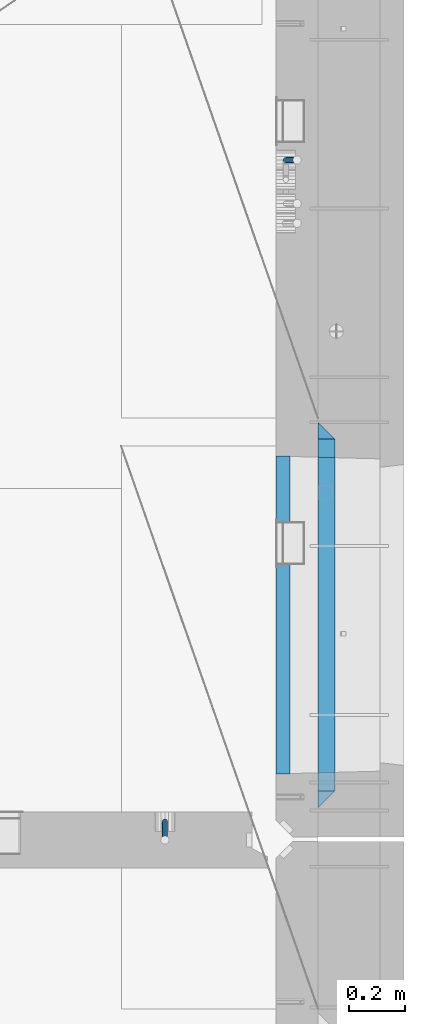
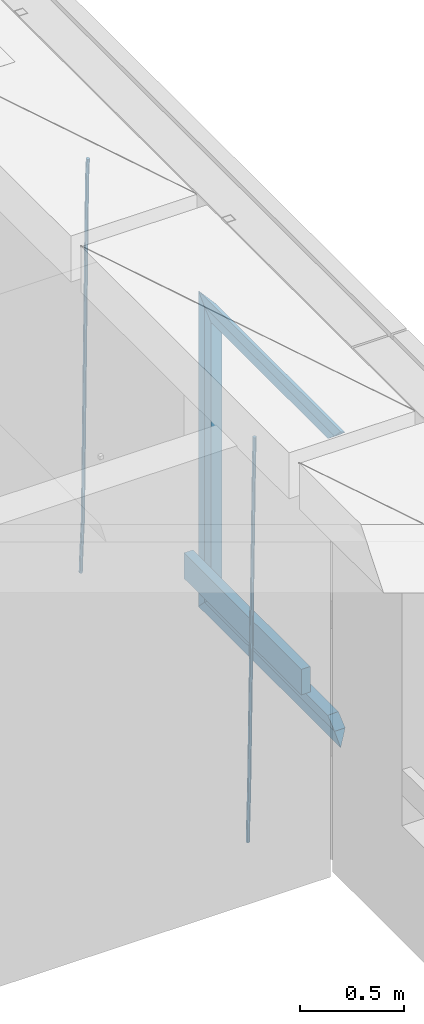
# One storey, part 132 of 352: 9 beams, 2 elements without a shape of their own.
"""IFC2X3 building model written with IfcOpenShell, lengths in millimetres."""

from ifc_helpers import new_model, si_unit, frame, origin_with_axes, place, context, subcontext, project, spatial, faceted_brep, material, type_object, element, aggregate, save


model = new_model("IFC2X3")

# Units and contexts
model_context = context("Model", 3, precision=1e-05, world=origin_with_axes())
body_context = subcontext(model_context, "Body", "Model", "MODEL_VIEW")
ifc_project = project(units=[si_unit("LENGTHUNIT", "METRE", prefix="MILLI"), si_unit("AREAUNIT", "SQUARE_METRE"), si_unit("VOLUMEUNIT", "CUBIC_METRE"), si_unit("MASSUNIT", "GRAM", prefix="KILO"), si_unit("TIMEUNIT", "SECOND"), si_unit("PLANEANGLEUNIT", "RADIAN"), si_unit("SOLIDANGLEUNIT", "STERADIAN"), si_unit("THERMODYNAMICTEMPERATUREUNIT", "DEGREE_CELSIUS"), si_unit("LUMINOUSINTENSITYUNIT", "LUMEN")], contexts=[model_context])

# Site, building, storey
site_placement = place(None, origin_with_axes())
site = spatial("IfcSite", under=ifc_project, at=site_placement, CompositionType="ELEMENT")
building_placement = place(site_placement, origin_with_axes())
building = spatial("IfcBuilding", under=site, at=building_placement, CompositionType="ELEMENT")
storey_placement = place(building_placement, origin_with_axes())
storey = spatial("IfcBuildingStorey", under=building, at=storey_placement, Name="6", CompositionType="ELEMENT", Elevation=0.0)

# Assembly, beam
assembly_1_placement = place(storey_placement, origin_with_axes())
assembly_1 = element("IfcElementAssembly", 1, at=assembly_1_placement, inside=storey, AssemblyPlace="NOTDEFINED", PredefinedType="REINFORCEMENT_UNIT")
ifc_material_1 = material()
beam_type_1 = type_object("IfcBeamType", Name="D20", PredefinedType="NOTDEFINED")
beam_1_placement = place(assembly_1_placement, frame((34514.9999999961, 17044.9997581385, 96990.0), z_axis=(0.00020576299992186, -0.999642804629538, -0.0267249099901004), x_axis=(-4.30000201928125e-08, -0.0267249099948059, 0.999642825806181)))
beam_1 = element("IfcBeam", 2, at=beam_1_placement, type_object=beam_type_1, material=ifc_material_1, Name="JM20", ObjectType="D20", context=body_context, shape_type="Brep", body=[
    faceted_brep([(0.0, -10.0, 0.0), (-4.19531716033816e-08, -7.07106781186667, -7.07106781187031), (60.4266690400545, -7.0710677960451, -7.07106780570757), (60.4266690441291, -9.99999998418934, 6.15546014159918e-09), (0.0, 0.0, -10.0), (60.426669036824, 1.58106558956206e-08, -9.99999999384454), (4.196772351861e-08, 7.07106781186303, -7.07106781186667), (60.4266690363438, 7.07106782768096, -7.07106780570757), (0.0, 10.0, 0.0), (60.4266690388904, 10.0000000158179, 6.15182216279209e-09), (4.196772351861e-08, 7.07106781185939, 7.07106781185939), (60.4266690429649, 7.07106782768096, 7.07106781802577), (0.0, 0.0, 10.0), (60.4266690461809, 1.58179318532348e-08, 10.0000000061555), (-4.19531716033816e-08, -7.07106781187031, 7.07106781185939), (60.4266690466611, -7.07106779605238, 7.07106781802213), (61.0378400410118, -7.07106779588503, -7.07106780564936), (60.991799419251, -9.99999998403655, 6.21366780251265e-09), (61.0569027789461, 1.5985278878361e-08, -9.99999999378269), (61.0378209396877, 7.07106782784831, -7.07106780564936), (60.9917724058905, 10.0000000159635, 6.21366780251265e-09), (60.9457317841297, 7.07106782781193, 7.0710678180767), (60.9266690461809, 1.59488990902901e-08, 10.0000000062028), (60.9457508854539, -7.07106779591413, 7.0710678180767), (61.6489592143771, -7.07106614513759, -7.06310863441468), (61.5568818710308, -9.9999984576425, 0.00735959856683621), (61.6870830769039, 1.71821739058942e-06, -9.99179257185824), (61.6489210170112, 7.07106947854481, -7.06310888312146), (61.556827851804, 10.0000015422847, 0.00735924683976918), (61.4647505084577, 7.07106922979438, 7.07782747982128), (61.4266266459163, 1.36643211590126e-06, 10.0065114172685), (61.464788705809, -7.07106639389531, 7.07782772852806), (176.543135720174, -7.07075579406956, -5.56673531796696), (176.451058376813, -9.99968810657447, 1.50373291501455), (176.581259582701, 0.000312069292704109, -8.49541925541052), (176.543097522794, 7.07137982961285, -5.56673556667374), (176.451004357587, 10.00031189336, 1.50373256329476), (176.35892701424, 7.07137958085514, 8.57420079627263), (176.320803151699, 0.000311717507429421, 11.5028847337162), (176.358965211621, -7.07075604281999, 8.57420104497578), (177.098753836006, -7.07075429323595, -5.55949898843028), (176.98362511232, -9.99968666800123, 1.510669025065), (177.146421932586, 0.000313595905026887, -8.48805862247536), (177.098706077581, 7.07138133041735, -5.55949936166144), (176.983557571715, 10.0003133318824, 1.51066849724157), (176.868428848029, 7.07138095712435, 8.58083651073321), (176.820760751449, 0.000313067976094317, 11.5093961447819), (176.868476606425, -7.07075466652896, 8.58083688396073), (177.654312950661, -7.07075204110879, -5.54863964998367), (177.516135294456, -9.99968450931192, 1.52107783331303), (177.711524267797, 0.000315886711177882, -8.47701274570863), (177.654255632195, 7.07138358250813, -5.54864021007961), (177.516054233929, 10.0003154905207, 1.5210770412159), (177.377876577739, 7.0713830223176, 8.59079452451624), (177.320665260588, 0.000315094497636892, 11.5191676202448), (177.377933896176, -7.07075260129932, 8.59079508461218), (299.499456785634, -7.07025810522464, -3.16697112782276), (299.361279129444, -9.99919057342777, 3.90274635547394), (299.556668102785, 0.000809822595329024, -6.09534422354773), (299.499399467197, 7.07187751838501, -3.1669716879187), (299.361198068917, 10.0008094264049, 3.90274556338045), (299.223020412712, 7.07187695819448, 10.9724630466735), (299.165809095575, 0.000809030381788034, 13.9008361423985), (299.223077731163, -7.07025866542244, 10.9724636067695), (300.03174732349, -7.07025594743027, -3.15656661289177), (299.971788958996, -9.99918809853989, 3.91467979818117), (300.056572611924, 0.000811849109595641, -6.08557274808481), (300.031722507032, 7.07187967631762, -3.15656653768019), (299.971753863239, 10.0008119014747, 3.91467990454839), (299.91179549876, 7.07187975035777, 10.9859263156177), (299.886970210311, 0.000811953817901667, 13.9149324508144), (299.911820315203, -7.0702558733974, 10.9859262404061), (300.564137759997, -7.07025623699155, -3.15794273276697), (300.582413367199, -9.99918843065097, 3.91310145956595), (300.556570941641, 0.000811577163403854, -6.0868651410201), (300.564145451674, 7.07187938674906, -3.15794274158179), (300.582424244858, 10.0008115693345, 3.91310144710224), (300.600699852032, 7.07187937566778, 10.9841456394352), (300.608266670402, 0.000811561512819026, 13.9130680476919), (300.600692160384, -7.07025624805829, 10.98414564825), (2294.16589219622, -7.0713405251372, -8.31099358700158), (2294.1841678034, -10.0002727187966, -1.23994939466866), (2294.15832537785, -0.000272710982244462, -11.2399159952547), (2294.16589988787, 7.07079509858886, -8.31099359582004), (2294.18417868105, 9.99972728118883, -1.23994940713601), (2294.20245428824, 7.07079508752213, 5.83109478519327), (2294.2100211066, -0.00027272663282929, 8.76001719345368), (2294.20244659658, -7.07134053620393, 5.83109479401173), (2294.7782683276, -7.07134085819416, -8.31257645345977), (2294.72126025338, -10.000273010919, -1.24133766827799), (2294.84007459224, -0.000273081772320438, -11.2416781768807), (2294.87047377572, 7.07079471537872, -8.31281477453012), (2294.85165844864, 9.9997269181622, -1.24167470516841), (2294.7946503744, 7.07079476544459, 5.82956408001337), (2294.73284410976, -0.000273010977252852, 8.75866580342336), (2294.7024449263, -7.07134080815013, 5.82980240107645), (2295.39054023061, -7.0793250091956, -8.30442771922026), (2295.25826128852, -10.0072756143927, -1.23419071494573), (2295.52170777075, -0.00916171800054144, -11.2326063125765), (2295.57492774284, 7.06160849139269, -8.30343918807193), (2295.51902460904, 9.99102432676591, -1.23279272078435), (2295.38674566693, 7.06307372157607, 5.83744428349019), (2295.25557812679, -0.0070895696117077, 8.76562287684646), (2295.20235815471, -7.07785977901949, 5.83645575234186), (2317.1947101649, -7.36365585014573, -8.01423575520312), (2317.06243122277, -10.2916064553428, -0.94399875092131), (2317.32587770502, -0.293492558957951, -10.9424143485521), (2317.37909767711, 6.77727765044983, -8.01324722405116), (2317.32319454331, 9.70669348581578, -0.942600756767206), (2317.1909156012, 6.77874288063322, 6.12763624751096), (2317.05974806109, -0.291420410569117, 9.0558148408636), (2317.00652808898, -7.36219061996962, 6.12664771636264), (2317.83015404257, -7.37194216843636, -8.00577862486898), (2317.72252095213, -10.300214160583, -0.935213608652703), (2317.90419832576, -0.301033978277701, -10.9347174723516), (2317.90127966482, 6.77046829039318, -8.00629749759901), (2317.82310777172, 9.70017451494641, -0.935947405505431), (2317.71547468127, 6.77190252279979, 6.13461761071085), (2317.64143039809, -0.29900566735887, 9.06355645819713), (2317.64434905903, -7.37050793602975, 6.13513648344451), (2318.46565174212, -7.3700661537805, -7.99751648408346), (2318.38266643914, -10.2982456018653, -0.926623872735945), (2318.48256818345, -0.299336209594912, -10.9272153854981), (2318.42350634121, 6.77200652527245, -7.99954269419686), (2318.32306384158, 9.70166538090416, -0.929489366557391), (2318.2400785386, 6.77348593281204, 6.14140324480104), (2318.22316209726, -0.297244011366274, 9.07110214621207), (2318.2822239395, -7.36858674623363, 6.1434294549108), (2418.48643733139, -7.07180401323421, -6.70013846199799), (2418.4034520284, -9.99998346132634, 0.370754149349523), (2418.5033537727, -0.00107406904135132, -9.62983736341266), (2418.44429193046, 7.07026866581873, -6.70216467211139), (2418.34384943081, 9.99992752145772, 0.367888655531715), (2418.26086412782, 7.0717480733656, 7.43878126688651), (2418.24394768651, 0.00101812917273492, 10.3684801682975), (2418.30300952874, -7.07032460568735, 7.44080747699627)], [[[0, 1, 2, 3]], [[1, 4, 5, 2]], [[4, 6, 7, 5]], [[6, 8, 9, 7]], [[8, 10, 11, 9]], [[10, 12, 13, 11]], [[12, 14, 15, 13]], [[14, 0, 3, 15]], [[14, 12, 10, 8, 6, 4, 1, 0]], [[3, 2, 16, 17]], [[2, 5, 18, 16]], [[5, 7, 19, 18]], [[7, 9, 20, 19]], [[9, 11, 21, 20]], [[11, 13, 22, 21]], [[13, 15, 23, 22]], [[15, 3, 17, 23]], [[17, 16, 24, 25]], [[16, 18, 26, 24]], [[18, 19, 27, 26]], [[19, 20, 28, 27]], [[20, 21, 29, 28]], [[21, 22, 30, 29]], [[22, 23, 31, 30]], [[23, 17, 25, 31]], [[25, 24, 32, 33]], [[24, 26, 34, 32]], [[26, 27, 35, 34]], [[27, 28, 36, 35]], [[28, 29, 37, 36]], [[29, 30, 38, 37]], [[30, 31, 39, 38]], [[31, 25, 33, 39]], [[33, 32, 40, 41]], [[32, 34, 42, 40]], [[34, 35, 43, 42]], [[35, 36, 44, 43]], [[36, 37, 45, 44]], [[37, 38, 46, 45]], [[38, 39, 47, 46]], [[39, 33, 41, 47]], [[41, 40, 48, 49]], [[40, 42, 50, 48]], [[42, 43, 51, 50]], [[43, 44, 52, 51]], [[44, 45, 53, 52]], [[45, 46, 54, 53]], [[46, 47, 55, 54]], [[47, 41, 49, 55]], [[49, 48, 56, 57]], [[48, 50, 58, 56]], [[50, 51, 59, 58]], [[51, 52, 60, 59]], [[52, 53, 61, 60]], [[53, 54, 62, 61]], [[54, 55, 63, 62]], [[55, 49, 57, 63]], [[57, 56, 64, 65]], [[56, 58, 66, 64]], [[58, 59, 67, 66]], [[59, 60, 68, 67]], [[60, 61, 69, 68]], [[61, 62, 70, 69]], [[62, 63, 71, 70]], [[63, 57, 65, 71]], [[65, 64, 72, 73]], [[64, 66, 74, 72]], [[66, 67, 75, 74]], [[67, 68, 76, 75]], [[68, 69, 77, 76]], [[69, 70, 78, 77]], [[70, 71, 79, 78]], [[71, 65, 73, 79]], [[73, 72, 80, 81]], [[72, 74, 82, 80]], [[74, 75, 83, 82]], [[75, 76, 84, 83]], [[76, 77, 85, 84]], [[77, 78, 86, 85]], [[78, 79, 87, 86]], [[79, 73, 81, 87]], [[81, 80, 88, 89]], [[80, 82, 90, 88]], [[82, 83, 91, 90]], [[83, 84, 92, 91]], [[84, 85, 93, 92]], [[85, 86, 94, 93]], [[86, 87, 95, 94]], [[87, 81, 89, 95]], [[89, 88, 96, 97]], [[88, 90, 98, 96]], [[90, 91, 99, 98]], [[91, 92, 100, 99]], [[92, 93, 101, 100]], [[93, 94, 102, 101]], [[94, 95, 103, 102]], [[95, 89, 97, 103]], [[97, 96, 104, 105]], [[96, 98, 106, 104]], [[98, 99, 107, 106]], [[99, 100, 108, 107]], [[100, 101, 109, 108]], [[101, 102, 110, 109]], [[102, 103, 111, 110]], [[103, 97, 105, 111]], [[105, 104, 112, 113]], [[104, 106, 114, 112]], [[106, 107, 115, 114]], [[107, 108, 116, 115]], [[108, 109, 117, 116]], [[109, 110, 118, 117]], [[110, 111, 119, 118]], [[111, 105, 113, 119]], [[113, 112, 120, 121]], [[112, 114, 122, 120]], [[114, 115, 123, 122]], [[115, 116, 124, 123]], [[116, 117, 125, 124]], [[117, 118, 126, 125]], [[118, 119, 127, 126]], [[119, 113, 121, 127]], [[121, 120, 128, 129]], [[120, 122, 130, 128]], [[122, 123, 131, 130]], [[123, 124, 132, 131]], [[124, 125, 133, 132]], [[125, 126, 134, 133]], [[126, 127, 135, 134]], [[127, 121, 129, 135]], [[130, 131, 132, 133, 134, 135, 129, 128]]]),
])
aggregate(assembly_1, [beam_1])

# Assembly, beams
assembly_2_placement = place(storey_placement, origin_with_axes())
assembly_2 = element("IfcElementAssembly", 3, at=assembly_2_placement, inside=storey, AssemblyPlace="NOTDEFINED", PredefinedType="REINFORCEMENT_UNIT")
beam_2_placement = place(assembly_2_placement, frame((34944.9999977209, 19397.5002651175, 96995.0), z_axis=(0.999642804629538, 0.000205762999925497, -0.0267249099901003), x_axis=(0.0267249109941254, -4.30000210532798e-08, 0.999642825779465)))
beam_2 = element("IfcBeam", 4, at=beam_2_placement, type_object=beam_type_1, material=ifc_material_1, Name="JM20", ObjectType="D20", context=body_context, shape_type="Brep", body=[
    faceted_brep([(0.0, -10.0, 0.0), (-4.19531716033816e-08, -7.07106781186667, -7.07106781187031), (60.4266690400545, -7.0710677960451, -7.07106780570757), (60.4266690441291, -9.99999998418934, 6.15546014159918e-09), (0.0, 0.0, -10.0), (60.426669036824, 1.58106558956206e-08, -9.99999999384454), (4.196772351861e-08, 7.07106781186303, -7.07106781186667), (60.4266690363438, 7.07106782768096, -7.07106780570757), (0.0, 10.0, 0.0), (60.4266690388904, 10.0000000158179, 6.15182216279209e-09), (4.196772351861e-08, 7.07106781185939, 7.07106781185939), (60.4266690429649, 7.07106782768096, 7.07106781802577), (0.0, 0.0, 10.0), (60.4266690461809, 1.58179318532348e-08, 10.0000000061555), (-4.19531716033816e-08, -7.07106781187031, 7.07106781185939), (60.4266690466611, -7.07106779605238, 7.07106781802213), (61.0378400410118, -7.07106779588503, -7.07106780564936), (60.991799419251, -9.99999998403655, 6.21366780251265e-09), (61.0569027789461, 1.5985278878361e-08, -9.99999999378269), (61.0378209396877, 7.07106782784831, -7.07106780564936), (60.9917724058905, 10.0000000159635, 6.21366780251265e-09), (60.9457317841297, 7.07106782781193, 7.0710678180767), (60.9266690461809, 1.59488990902901e-08, 10.0000000062028), (60.9457508854539, -7.07106779591413, 7.0710678180767), (61.6489592143771, -7.07106614513759, -7.06310863441468), (61.5568818710308, -9.9999984576425, 0.00735959856683621), (61.6870830769039, 1.71821739058942e-06, -9.99179257185824), (61.6489210170112, 7.07106947854481, -7.06310888312146), (61.556827851804, 10.0000015422847, 0.00735924683976918), (61.4647505084577, 7.07106922979438, 7.07782747982128), (61.4266266459163, 1.36643211590126e-06, 10.0065114172685), (61.464788705809, -7.07106639389531, 7.07782772852806), (176.543135720174, -7.07075579406956, -5.56673531796696), (176.451058376813, -9.99968810657447, 1.50373291501455), (176.581259582701, 0.000312069292704109, -8.49541925541052), (176.543097522794, 7.07137982961285, -5.56673556667374), (176.451004357587, 10.00031189336, 1.50373256329476), (176.35892701424, 7.07137958085514, 8.57420079627263), (176.320803151699, 0.000311717507429421, 11.5028847337162), (176.358965211621, -7.07075604281999, 8.57420104497578), (177.098753836006, -7.07075429323595, -5.55949898843028), (176.98362511232, -9.99968666800123, 1.510669025065), (177.146421932586, 0.000313595905026887, -8.48805862247536), (177.098706077581, 7.07138133041735, -5.55949936166144), (176.983557571715, 10.0003133318824, 1.51066849724157), (176.868428848029, 7.07138095712435, 8.58083651073321), (176.820760751449, 0.000313067976094317, 11.5093961447819), (176.868476606425, -7.07075466652896, 8.58083688396073), (177.654312950661, -7.07075204110879, -5.54863964998367), (177.516135294456, -9.99968450931192, 1.52107783331303), (177.711524267797, 0.000315886711177882, -8.47701274570863), (177.654255632195, 7.07138358250813, -5.54864021007961), (177.516054233929, 10.0003154905207, 1.5210770412159), (177.377876577739, 7.0713830223176, 8.59079452451624), (177.320665260588, 0.000315094497636892, 11.5191676202448), (177.377933896176, -7.07075260129932, 8.59079508461218), (299.436796249574, -7.07025836271714, -3.1681962331204), (299.298618593355, -9.99919083092027, 3.90152125031091), (299.494007566798, 0.000809565110102994, -6.09656932889993), (299.436738931283, 7.07187726089978, -3.16819679320906), (299.298537533061, 10.0008091689197, 3.90152045822106), (299.160359876842, 7.07187670072017, 10.9712379416487), (299.103148559603, 0.000808772889286047, 13.8996110374392), (299.160417195119, -7.07025892290039, 10.9712385017483), (299.98743051647, -7.07025613056248, -3.15743315966392), (299.971788958996, -9.99918809853989, 3.91467979818117), (299.993912075952, 0.000811591617093654, -6.08679785393178), (299.987423933868, 7.07187949325817, -3.1574327280432), (299.971753863239, 10.0008119014747, 3.91467990454839), (299.95611230444, 7.07187992653053, 10.9867922621015), (299.949630744944, 0.000812204350950196, 13.9161569563694), (299.956118887014, -7.07025569729012, 10.9867918304735), (300.538107039494, -7.07025785017686, -3.16575821840888), (300.644985195438, -9.99919020432935, 3.90450175465594), (300.493854948218, 0.000810030429420294, -6.09435592770024), (300.538151196495, 7.071877773491, -3.16575855385963), (300.645047642858, 10.0008097955724, 3.90450128024895), (300.751925798773, 7.07187744142357, 10.9747612533101), (300.796177890064, 0.000809560813650023, 13.9033589625978), (300.751881641787, -7.07025818224065, 10.9747615887682), (2293.36490490142, -7.07648090940347, -33.2930642912361), (2293.47178305736, -10.0054132635523, -26.2228043181785), (2293.32065281013, -0.00541302880083094, -36.2216620005347), (2293.36494905842, 7.06565471425711, -33.2930646266868), (2293.47184550477, 9.99458673634581, -26.2228047925819), (2293.57872366071, 7.06565438219332, -19.1525448195243), (2293.62297575199, -0.00541349841296324, -16.2239471102366), (2293.57867950371, -7.0764812414709, -19.1525444840736), (2294.0658245362, -7.07648309818615, -33.3036607065333), (2294.05312277409, -10.0054150789219, -26.2315929392535), (2294.10928714235, -0.00541549149056664, -36.2335844756526), (2294.15805078732, 7.06565223761572, -33.3050546393533), (2294.18355038921, 9.99458451388637, -26.2335642579346), (2294.17084862708, 7.06565253314329, -19.1614964906439), (2294.12738602093, -0.00541507354500936, -16.2315727215355), (2294.07862237596, -7.07648280265857, -19.1601025578348), (2294.76670261032, -7.08562269121467, -33.294332712383), (2294.63442802057, -10.0129954178956, -26.2238563411993), (2294.89787471293, -0.0156988342423574, -36.2230891548279), (2294.95110548967, 7.05531064255774, -33.2944998654275), (2294.89521307347, 9.98530428734011, -26.2240927312887), (2294.76293848372, 7.0579315606592, -19.1536163601049), (2294.63176638114, -0.0119922963167483, -16.2248599176673), (2294.57853560438, -7.08300177311321, -19.1534492070678), (2316.52657204497, -7.36937582653991, -33.0047303660212), (2316.39429745522, -10.2967485532172, -25.9342539948302), (2316.65774414754, -0.299451969567599, -35.9334868084661), (2316.7109749243, 6.7715575072325, -33.0048975190657), (2316.65508250811, 9.70155115201487, -25.9344903849269), (2316.52280791836, 6.7741784253376, -18.8640140137468), (2316.39163581574, -0.295745431634714, -15.9352575713092), (2316.33840503903, -7.36675490843481, -18.863846860706), (2317.16202064224, -7.37766220584308, -32.9962731735213), (2317.05438744847, -10.3053562613532, -25.9254688497131), (2317.23607125619, -0.306993473008333, -35.925789846493), (2317.23316144495, 6.76474808850253, -32.9979477328052), (2317.15499573652, 9.6950321815566, -25.9278370341635), (2317.04736254275, 6.7673381260538, -18.8570327103698), (2316.97331192881, -0.303330606784584, -15.9275160373909), (2316.97622174003, -7.37507216829545, -18.8553581510787), (2317.79752306276, -7.37578610372293, -32.9880110666527), (2317.71453320107, -10.3033876998124, -25.9168792378296), (2317.81444760226, -0.305295583297266, -35.918287695793), (2317.75539265381, 6.76628640723357, -32.9911928173897), (2317.65495180529, 9.69652304524061, -25.9213789128698), (2317.5719619436, 6.76892144914746, -18.8502470840467), (2317.55503740412, -0.301569071270933, -15.9199704549137), (2317.61409235255, -7.3731510618054, -18.847065333317), (2417.8183084176, -7.07752398473531, -31.6906369377139), (2417.73531855589, -10.0051255808248, -24.6195051088798), (2417.83523295709, -0.007033464313281, -34.6209135668432), (2417.77617800863, 7.06454852621755, -31.6938186884508), (2417.67573716014, 9.99478516423187, -24.6240047839383), (2417.59274729842, 7.06718356813872, -17.5528729551006), (2417.57582275895, -0.00330695228694822, -14.6225963259749), (2417.6348777074, -7.07488894281778, -17.5496912043673)], [[[0, 1, 2, 3]], [[1, 4, 5, 2]], [[4, 6, 7, 5]], [[6, 8, 9, 7]], [[8, 10, 11, 9]], [[10, 12, 13, 11]], [[12, 14, 15, 13]], [[14, 0, 3, 15]], [[14, 12, 10, 8, 6, 4, 1, 0]], [[3, 2, 16, 17]], [[2, 5, 18, 16]], [[5, 7, 19, 18]], [[7, 9, 20, 19]], [[9, 11, 21, 20]], [[11, 13, 22, 21]], [[13, 15, 23, 22]], [[15, 3, 17, 23]], [[17, 16, 24, 25]], [[16, 18, 26, 24]], [[18, 19, 27, 26]], [[19, 20, 28, 27]], [[20, 21, 29, 28]], [[21, 22, 30, 29]], [[22, 23, 31, 30]], [[23, 17, 25, 31]], [[25, 24, 32, 33]], [[24, 26, 34, 32]], [[26, 27, 35, 34]], [[27, 28, 36, 35]], [[28, 29, 37, 36]], [[29, 30, 38, 37]], [[30, 31, 39, 38]], [[31, 25, 33, 39]], [[33, 32, 40, 41]], [[32, 34, 42, 40]], [[34, 35, 43, 42]], [[35, 36, 44, 43]], [[36, 37, 45, 44]], [[37, 38, 46, 45]], [[38, 39, 47, 46]], [[39, 33, 41, 47]], [[41, 40, 48, 49]], [[40, 42, 50, 48]], [[42, 43, 51, 50]], [[43, 44, 52, 51]], [[44, 45, 53, 52]], [[45, 46, 54, 53]], [[46, 47, 55, 54]], [[47, 41, 49, 55]], [[49, 48, 56, 57]], [[48, 50, 58, 56]], [[50, 51, 59, 58]], [[51, 52, 60, 59]], [[52, 53, 61, 60]], [[53, 54, 62, 61]], [[54, 55, 63, 62]], [[55, 49, 57, 63]], [[57, 56, 64, 65]], [[56, 58, 66, 64]], [[58, 59, 67, 66]], [[59, 60, 68, 67]], [[60, 61, 69, 68]], [[61, 62, 70, 69]], [[62, 63, 71, 70]], [[63, 57, 65, 71]], [[65, 64, 72, 73]], [[64, 66, 74, 72]], [[66, 67, 75, 74]], [[67, 68, 76, 75]], [[68, 69, 77, 76]], [[69, 70, 78, 77]], [[70, 71, 79, 78]], [[71, 65, 73, 79]], [[73, 72, 80, 81]], [[72, 74, 82, 80]], [[74, 75, 83, 82]], [[75, 76, 84, 83]], [[76, 77, 85, 84]], [[77, 78, 86, 85]], [[78, 79, 87, 86]], [[79, 73, 81, 87]], [[81, 80, 88, 89]], [[80, 82, 90, 88]], [[82, 83, 91, 90]], [[83, 84, 92, 91]], [[84, 85, 93, 92]], [[85, 86, 94, 93]], [[86, 87, 95, 94]], [[87, 81, 89, 95]], [[89, 88, 96, 97]], [[88, 90, 98, 96]], [[90, 91, 99, 98]], [[91, 92, 100, 99]], [[92, 93, 101, 100]], [[93, 94, 102, 101]], [[94, 95, 103, 102]], [[95, 89, 97, 103]], [[97, 96, 104, 105]], [[96, 98, 106, 104]], [[98, 99, 107, 106]], [[99, 100, 108, 107]], [[100, 101, 109, 108]], [[101, 102, 110, 109]], [[102, 103, 111, 110]], [[103, 97, 105, 111]], [[105, 104, 112, 113]], [[104, 106, 114, 112]], [[106, 107, 115, 114]], [[107, 108, 116, 115]], [[108, 109, 117, 116]], [[109, 110, 118, 117]], [[110, 111, 119, 118]], [[111, 105, 113, 119]], [[113, 112, 120, 121]], [[112, 114, 122, 120]], [[114, 115, 123, 122]], [[115, 116, 124, 123]], [[116, 117, 125, 124]], [[117, 118, 126, 125]], [[118, 119, 127, 126]], [[119, 113, 121, 127]], [[121, 120, 128, 129]], [[120, 122, 130, 128]], [[122, 123, 131, 130]], [[123, 124, 132, 131]], [[124, 125, 133, 132]], [[125, 126, 134, 133]], [[126, 127, 135, 134]], [[127, 121, 129, 135]], [[130, 131, 132, 133, 134, 135, 129, 128]]]),
])
ifc_material_2 = material(Name="TIMBER/T24")
beam_type_2 = type_object("IfcBeamType", PredefinedType="NOTDEFINED")
beam_3_placement = place(assembly_2_placement, frame((34935.0002758707, 17215.0011464907, 97685.0), z_axis=(0.0, 0.0, 1.0), x_axis=(0.0, 1.0, 0.0)))
beam_3 = element("IfcBeam", 5, at=beam_3_placement, type_object=beam_type_2, material=ifc_material_2, context=body_context, shape_type="Brep", body=[
    faceted_brep([(-3.63797880709171e-12, 24.9999999999964, -75.0), (-3.63797880709171e-12, 24.9999999999964, 75.0), (1130.0, 25.0, 75.0), (1130.0, 25.0, -75.0), (0.0, -25.0000000000073, 75.0), (1130.0, -25.0, 75.0), (0.0, -25.0000000000073, -75.0), (1130.0, -25.0, -75.0)], [[[0, 1, 2, 3]], [[1, 4, 5, 2]], [[4, 6, 7, 5]], [[6, 0, 3, 7]], [[5, 7, 3, 2]], [[6, 4, 1, 0]]]),
])
ifc_material_3 = material(Name="CONCRETE/C25/30")
beam_type_3 = type_object("IfcBeamType", PredefinedType="NOTDEFINED")
beam_4_placement = place(assembly_2_placement, frame((35090.0, 17095.0018965848, 99145.0), z_axis=(0.0, 0.0, -1.0), x_axis=(0.0, 1.0, 0.0)))
beam_4 = element("IfcBeam", 6, at=beam_4_placement, type_object=beam_type_3, material=ifc_material_3, Name="SK", context=body_context, shape_type="Brep", body=[
    faceted_brep([(60.0000000000073, 30.0, 30.0), (0.0, -30.0, -30.0), (60.0000000000073, -30.0, 30.0), (1309.99847412109, 30.0, 30.0), (1369.99847412109, -30.0, -30.0), (1309.99847412109, -30.0, 30.0)], [[[0, 1, 2]], [[1, 0, 3, 4]], [[2, 1, 4, 5]], [[0, 2, 5, 3]], [[3, 5, 4]]]),
])
beam_5_placement = place(assembly_2_placement, frame((35090.0, 17155.0018965848, 99085.0), z_axis=(0.0, 0.0, -1.0), x_axis=(0.0, 1.0, 0.0)))
beam_5 = element("IfcBeam", 7, at=beam_5_placement, type_object=beam_type_3, material=ifc_material_3, Name="SK", context=body_context, shape_type="Brep", body=[
    faceted_brep([(1185.94442006696, -29.999999998452, 24.0540540541406), (1184.32279844542, 29.999999998452, 25.6756756756804), (65.6741497967687, 29.999999998452, 25.6756756756804), (64.0525281752307, -29.999999998452, 24.0540540541406), (65.6741497967687, 29.999999998452, 26.2921283848846), (64.0525281752307, -29.999999998452, 24.9021669953072), (0.0, 30.0, -30.0), (0.0, -30.0, -30.0), (1249.99847412109, 29.999999998452, -30.0), (1249.99847412109, -29.999999998452, -30.0), (1185.94442006696, -29.999999998452, 24.9034748915001), (1184.32279844542, 29.999999998452, 26.2934362810629)], [[[0, 1, 2, 3]], [[3, 2, 4, 5]], [[4, 6, 7, 5]], [[7, 6, 8, 9]], [[0, 3, 5, 7, 9, 10]], [[1, 0, 10, 11]], [[6, 4, 2, 1, 11, 8]], [[8, 11, 10, 9]]]),
])
beam_6_placement = place(assembly_2_placement, frame((35090.0, 18435.0003707059, 99175.0), z_axis=(0.0, -1.0, 0.0), x_axis=(0.0, 0.0, -1.0)))
beam_6 = element("IfcBeam", 8, at=beam_6_placement, type_object=beam_type_3, material=ifc_material_3, Name="SK", context=body_context, shape_type="Brep", body=[
    faceted_brep([(60.0000000000073, 30.0, 30.0), (0.0, -30.0, -30.0), (60.0000000000073, -30.0, 30.0), (1795.00000000001, 30.0, 30.0), (1855.0, -30.0, -30.0), (1795.00000000001, -30.0, 30.0)], [[[0, 1, 2]], [[3, 4, 1, 0]], [[4, 5, 2, 1]], [[5, 3, 0, 2]], [[5, 4, 3]]]),
])
beam_7_placement = place(assembly_2_placement, frame((35090.0, 18465.0003707059, 97350.0), z_axis=(0.0, 0.0, 1.0), x_axis=(0.0, -1.0, 0.0)))
beam_7 = element("IfcBeam", 9, at=beam_7_placement, type_object=beam_type_3, material=ifc_material_3, Name="SK", context=body_context, shape_type="Brep", body=[
    faceted_brep([(1309.99847412109, 30.0, 30.0), (1309.99847412109, -30.0, 30.0), (1369.99847412109, -30.0, -30.0), (60.0000000000073, 30.0, 30.0), (60.0000000000073, -30.0, 30.0), (0.0, -30.0, -30.0)], [[[0, 1, 2]], [[3, 4, 1, 0]], [[4, 5, 2, 1]], [[5, 3, 0, 2]], [[3, 5, 4]]]),
])
beam_8_placement = place(assembly_2_placement, frame((35090.0, 18405.0003707059, 97410.0), z_axis=(0.0, 0.0, 1.0), x_axis=(0.0, -1.0, 0.0)))
beam_8 = element("IfcBeam", 10, at=beam_8_placement, type_object=beam_type_3, material=ifc_material_3, Name="SK", context=body_context, shape_type="Brep", body=[
    faceted_brep([(1185.94594588314, -29.9999988381387, 24.0540541168593), (1184.32432432432, 29.9999988381387, 25.6756756756804), (65.6756756756768, 30.0, 25.6756756756804), (64.0540540540533, -30.0, 24.0540540540533), (1185.94594594586, -29.999999998452, 24.9021669952926), (1184.32432432433, 29.999999998452, 26.2921283848846), (1249.99847412109, -29.999999998452, -30.0), (1249.99847412109, 29.999999998452, -30.0), (0.0, 30.0, -30.0), (65.6756756756768, 30.0, 26.293436281092), (64.0540540540533, -30.0, 24.9034748914419), (0.0, -30.0, -30.0)], [[[0, 1, 2, 3]], [[1, 0, 4, 5]], [[5, 4, 6, 7]], [[2, 1, 5, 7, 8, 9]], [[3, 2, 9, 10]], [[6, 4, 0, 3, 10, 11]], [[11, 8, 7, 6]], [[11, 10, 9, 8]]]),
])
beam_type_4 = type_object("IfcBeamType", PredefinedType="NOTDEFINED")
beam_9_placement = place(assembly_2_placement, frame((35090.0, 18370.0003707059, 99115.0), z_axis=(0.0, -1.0, 0.0), x_axis=(0.0, 0.0, -1.0)))
beam_9 = element("IfcBeam", 11, at=beam_9_placement, type_object=beam_type_4, material=ifc_material_3, Name="SK", context=body_context, shape_type="Brep", body=[
    faceted_brep([(0.0, -30.0, -35.0), (54.9034748914273, -30.0, 29.0540540540533), (56.2934362811066, 30.0, 30.6756756756768), (0.0, 30.0, -35.0), (1735.0, 30.0, -35.0), (1735.0, -30.0, -35.0), (1680.09652510857, -30.0, 29.0540540540533), (1678.70656371891, 30.0, 30.6756756756768)], [[[0, 1, 2, 3]], [[4, 5, 0, 3]], [[1, 0, 5, 6]], [[2, 1, 6, 7]], [[3, 2, 7, 4]], [[5, 4, 7, 6]]]),
])
aggregate(assembly_2, [beam_2, beam_4, beam_5, beam_6, beam_9, beam_7, beam_8, beam_3])

save(model, "model.ifc")
